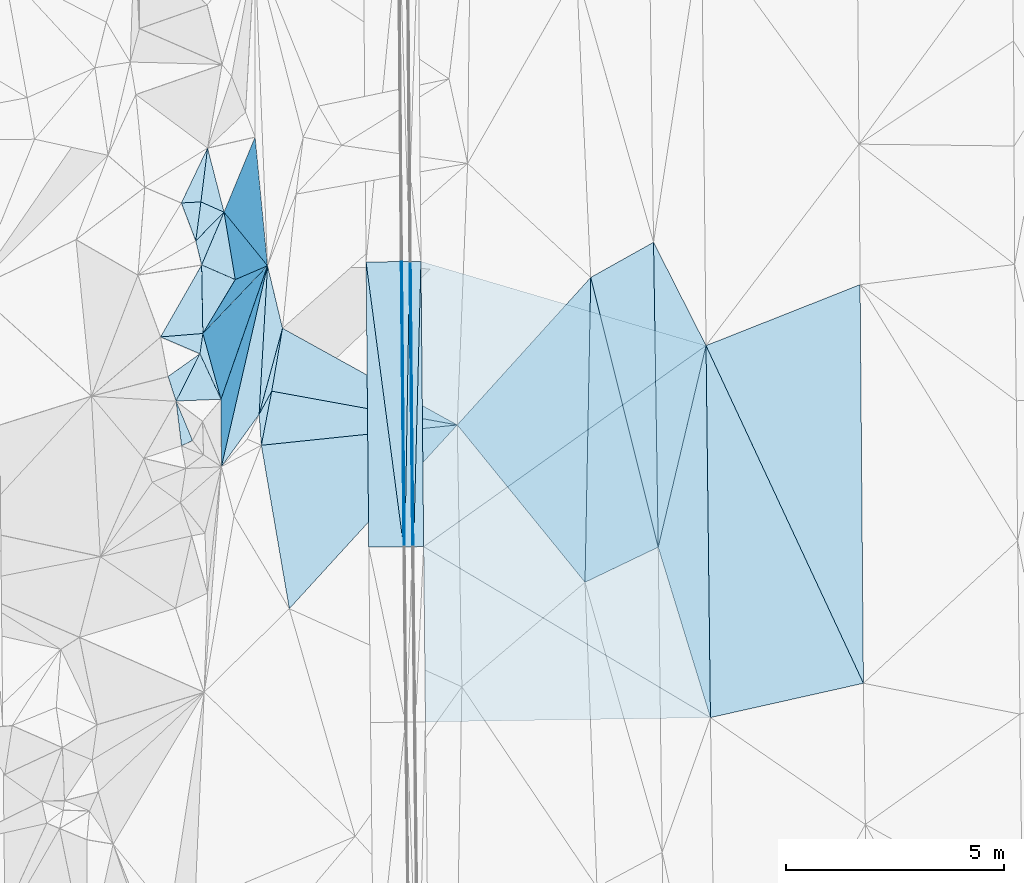
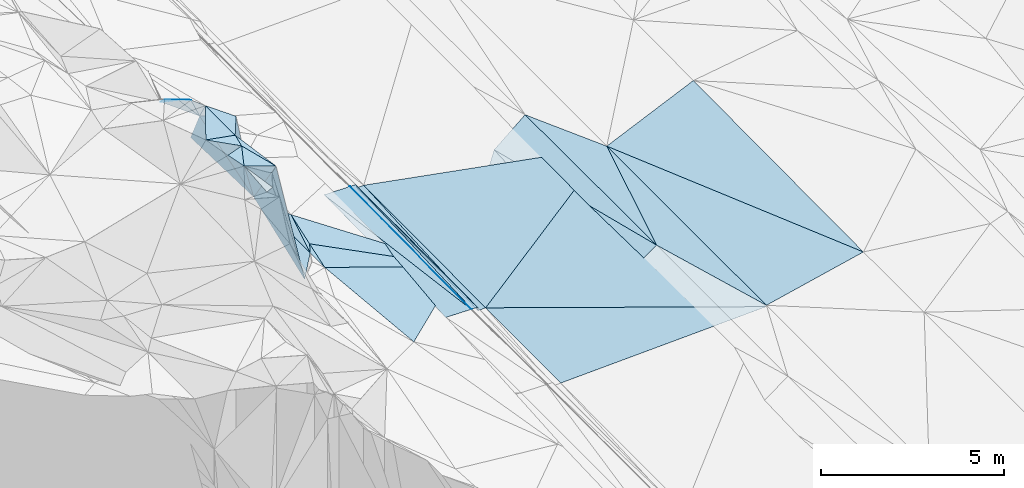
# One storey, part 21 of 275: 45 plates.
"""IFC2X3 building model written with IfcOpenShell, lengths in millimetres."""

from ifc_helpers import new_model, si_unit, frame, origin_with_axes, place, context, subcontext, project, spatial, polyline, outline, extrude, material, type_object, element, save


model = new_model("IFC2X3")

# Units and contexts
model_context = context("Model", 3, precision=1e-05, world=origin_with_axes())
body_context = subcontext(model_context, "Body", "Model", "MODEL_VIEW")
ifc_project = project(units=[si_unit("LENGTHUNIT", "METRE", prefix="MILLI"), si_unit("AREAUNIT", "SQUARE_METRE"), si_unit("VOLUMEUNIT", "CUBIC_METRE"), si_unit("MASSUNIT", "GRAM", prefix="KILO"), si_unit("TIMEUNIT", "SECOND"), si_unit("PLANEANGLEUNIT", "RADIAN"), si_unit("SOLIDANGLEUNIT", "STERADIAN"), si_unit("THERMODYNAMICTEMPERATUREUNIT", "DEGREE_CELSIUS"), si_unit("LUMINOUSINTENSITYUNIT", "LUMEN")], contexts=[model_context])

# Site, building, storey
site_placement = place(None, origin_with_axes())
site = spatial("IfcSite", under=ifc_project, at=site_placement, CompositionType="ELEMENT")
building_placement = place(site_placement, origin_with_axes())
building = spatial("IfcBuilding", under=site, at=building_placement, Name="Undefined", CompositionType="ELEMENT")
storey_placement = place(building_placement, origin_with_axes())
storey = spatial("IfcBuildingStorey", under=building, at=storey_placement, Name="Undefined", CompositionType="ELEMENT", Elevation=0.0)

# Plates
ifc_material = material()
plate_type_1 = type_object("IfcPlateType", PredefinedType="NOTDEFINED")
plate_1_placement = place(storey_placement, frame((-93826.0260139726, 22871.525011695, 41384.7557479221), z_axis=(-0.970140566406097, -0.00414182379027127, -0.242507993082596), x_axis=(-0.014017652109984, 0.999140397865206, 0.0390124439516598)))
element("IfcPlate", 1, at=plate_1_placement, inside=storey, type_object=plate_type_1, material=ifc_material, Name="00_PR", context=body_context, shape_type="SweptSolid", body=[
    extrude(outline(polyline([(0.0, 0.0), (6552.26806640625, 1.18961906991899e-08), (6547.705078125, 123.608764648438), (0.0, 0.0)])), frame((-8.85201319254618e-08, 2.18876761149539e-07, -0.5000001331573), z_axis=(0.0, 0.0, 1.0), x_axis=(1.0, 0.0, 0.0)), (0.0, 0.0, 1.0), 1.0),
])
plate_2_placement = place(storey_placement, frame((-93856.0194695431, 22870.9196575083, 41504.7557501283), z_axis=(-0.970141710660161, -0.00414201915198373, -0.242503412171293), x_axis=(-0.00944488511412005, 0.999740938347601, 0.0207087019641435)))
element("IfcPlate", 2, at=plate_2_placement, inside=storey, type_object=plate_type_1, material=ifc_material, Name="00_PR", context=body_context, shape_type="SweptSolid", body=[
    extrude(outline(polyline([(0.0, 0.0), (6548.93798828125, -1.03318598121405e-08), (-2.16313171386719, 123.67414855957), (0.0, 0.0)])), frame((-8.85201319254618e-08, 2.18876761149539e-07, -0.5000001331573), z_axis=(0.0, 0.0, 1.0), x_axis=(1.0, 0.0, 0.0)), (0.0, 0.0, 1.0), 1.0),
])
plate_type_2 = type_object("IfcPlateType", PredefinedType="NOTDEFINED")
plate_3_placement = place(storey_placement, frame((-94087.3915116084, 29416.65937764, 41639.9972075096), z_axis=(-0.0201751474359176, 0.0205142055832547, -0.999585979691205), x_axis=(0.00486424610334273, -0.999775628945479, -0.0206162769800514)))
element("IfcPlate", 3, at=plate_3_placement, inside=storey, type_object=plate_type_2, material=ifc_material, Name="00_PR", context=body_context, shape_type="SweptSolid", body=[
    extrude(outline(polyline([(0.0, 0.0), (6549.1943359375, 3.34694050252438e-09), (0.108272440731525, 30.0058708190918), (0.0, 0.0)])), frame((-8.85201319254618e-08, 2.18876761149539e-07, -0.5000001331573), z_axis=(0.0, 0.0, 1.0), x_axis=(1.0, 0.0, 0.0)), (0.0, 0.0, 1.0), 1.0),
])
plate_4_placement = place(storey_placement, frame((-94055.5346332526, 22868.9346980199, 41504.9772079253), z_axis=(-0.0201973002750477, 0.0205140903788785, -0.999585534688016), x_axis=(-0.00486424610268061, 0.99977562894545, 0.0206162769816057)))
element("IfcPlate", 4, at=plate_4_placement, inside=storey, type_object=plate_type_2, material=ifc_material, Name="00_PR", context=body_context, shape_type="SweptSolid", body=[
    extrude(outline(polyline([(0.0, 0.0), (6549.1943359375, 3.34694050252438e-09), (0.140960708260536, 30.0058040618896), (0.0, 0.0)])), frame((-8.85201319254618e-08, 2.18876761149539e-07, -0.5000001331573), z_axis=(0.0, 0.0, 1.0), x_axis=(1.0, 0.0, 0.0)), (0.0, 0.0, 1.0), 1.0),
])
plate_type_3 = type_object("IfcPlateType", PredefinedType="NOTDEFINED")
plate_5_placement = place(storey_placement, frame((-94917.359086969, 29409.2703324959, 41656.5972077812), z_axis=(-0.0201751474359176, 0.0205142055832547, -0.999585979691205), x_axis=(0.99976043542042, 0.00890124210765779, -0.0199959910210385)))
element("IfcPlate", 5, at=plate_5_placement, inside=storey, type_object=plate_type_3, material=ifc_material, Name="00_PR", context=body_context, shape_type="SweptSolid", body=[
    extrude(outline(polyline([(0.0, 0.0), (800.160400390625, 3.5979610402137e-09), (806.432678222656, 6549.1513671875), (0.0, 0.0)])), frame((-8.85201319254618e-08, 2.18876761149539e-07, -0.5000001331573), z_axis=(0.0, 0.0, 1.0), x_axis=(1.0, 0.0, 0.0)), (0.0, 0.0, 1.0), 1.0),
])
plate_6_placement = place(storey_placement, frame((-94055.5346332526, 22868.9346980199, 41504.9772079253), z_axis=(-0.020197663765246, 0.0205112299366591, -0.999585586042992), x_axis=(-0.99975015351439, -0.00998950710098539, 0.0199960069972186)))
element("IfcPlate", 6, at=plate_6_placement, inside=storey, type_object=plate_type_3, material=ifc_material, Name="00_PR", context=body_context, shape_type="SweptSolid", body=[
    extrude(outline(polyline([(0.0, 0.0), (800.159790039063, 5.60248736292124e-09), (799.306213378906, 6550.025390625), (0.0, 0.0)])), frame((-8.85201319254618e-08, 2.18876761149539e-07, -0.5000001331573), z_axis=(0.0, 0.0, 1.0), x_axis=(1.0, 0.0, 0.0)), (0.0, 0.0, 1.0), 1.0),
])
plate_type_4 = type_object("IfcPlateType", PredefinedType="NOTDEFINED")
plate_7_placement = place(storey_placement, frame((-93887.3778118008, 29418.7125557996, 41519.9973749034), z_axis=(0.0324229017125608, 0.0210051230873963, -0.99925349148683), x_axis=(0.999438984670198, 0.00771590211008949, 0.0325911149860068)))
element("IfcPlate", 7, at=plate_7_placement, inside=storey, type_object=plate_type_4, material=ifc_material, Name="00_PR", context=body_context, shape_type="SweptSolid", body=[
    extrude(outline(polyline([(0.0, 0.0), (230.124069213867, 3.71073838323355e-10), (6.88101148605347, 6548.8681640625), (0.0, 0.0)])), frame((-8.85201319254618e-08, 2.18876761149539e-07, -0.5000001331573), z_axis=(0.0, 0.0, 1.0), x_axis=(1.0, 0.0, 0.0)), (0.0, 0.0, 1.0), 1.0),
])
plate_8_placement = place(storey_placement, frame((-93657.3828568659, 29420.4881701947, 41527.497374587), z_axis=(0.0324032083024924, 0.0210056422550089, -0.999254119373626), x_axis=(0.00944502212352981, -0.999740918493301, -0.020709597950165)))
element("IfcPlate", 8, at=plate_8_placement, inside=storey, type_object=plate_type_4, material=ifc_material, Name="00_PR", context=body_context, shape_type="SweptSolid", body=[
    extrude(outline(polyline([(0.0, 0.0), (6548.654296875, -1.17142917588353e-08), (6548.6298828125, 230.124954223633), (0.0, 0.0)])), frame((-8.85201319254618e-08, 2.18876761149539e-07, -0.5000001331573), z_axis=(0.0, 0.0, 1.0), x_axis=(1.0, 0.0, 0.0)), (0.0, 0.0, 1.0), 1.0),
])
plate_type_5 = type_object("IfcPlateType", PredefinedType="NOTDEFINED")
plate_9_placement = place(storey_placement, frame((-97082.5660207515, 26443.461021009, 42579.5374403282), z_axis=(-0.378120799749058, 0.0352070273940307, -0.925086550555789), x_axis=(0.910617236448785, -0.165832654415489, -0.378517871984786)))
element("IfcPlate", 9, at=plate_9_placement, inside=storey, type_object=plate_type_5, material=ifc_material, Name="00", context=body_context, shape_type="SweptSolid", body=[
    extrude(outline(polyline([(0.0, 0.0), (4676.13330078125, -1.7611455405131e-08), (-29.6355972290039, 1265.55200195313), (0.0, 0.0)])), frame((-8.85201319254618e-08, 2.18876761149539e-07, -0.5000001331573), z_axis=(0.0, 0.0, 1.0), x_axis=(1.0, 0.0, 0.0)), (0.0, 0.0, 1.0), 1.0),
])
plate_type_6 = type_object("IfcPlateType", PredefinedType="NOTDEFINED")
plate_10_placement = place(storey_placement, frame((-94025.5259870622, 22869.2341150587, 41504.3771091948), z_axis=(-0.000184409306113274, 0.0207073018638492, -0.999785563829928), x_axis=(-0.00944488511412005, 0.999740938347601, 0.0207087019641435)))
element("IfcPlate", 10, at=plate_10_placement, inside=storey, type_object=plate_type_6, material=ifc_material, Name="00_PR", context=body_context, shape_type="SweptSolid", body=[
    extrude(outline(polyline([(0.0, 0.0), (6549.1220703125, 9.50240064412355e-09), (6549.02978515625, 169.999771118164), (0.0, 0.0)])), frame((-8.85201319254618e-08, 2.18876761149539e-07, -0.5000001331573), z_axis=(0.0, 0.0, 1.0), x_axis=(1.0, 0.0, 0.0)), (0.0, 0.0, 1.0), 1.0),
])
plate_11_placement = place(storey_placement, frame((-93917.3884652432, 29418.1733544356, 41639.9971090388), z_axis=(-0.00020683915581574, 0.0207076720193423, -0.999785551774531), x_axis=(0.0094448851130357, -0.999740938347447, -0.0207087019720617)))
element("IfcPlate", 11, at=plate_11_placement, inside=storey, type_object=plate_type_6, material=ifc_material, Name="00_PR", context=body_context, shape_type="SweptSolid", body=[
    extrude(outline(polyline([(0.0, 0.0), (6548.93798828125, -1.03318598121405e-08), (6549.02978515625, 169.999954223633), (0.0, 0.0)])), frame((-8.85201319254618e-08, 2.18876761149539e-07, -0.5000001331573), z_axis=(0.0, 0.0, 1.0), x_axis=(1.0, 0.0, 0.0)), (0.0, 0.0, 1.0), 1.0),
])
plate_type_7 = type_object("IfcPlateType", PredefinedType="NOTDEFINED")
plate_12_placement = place(storey_placement, frame((-87114.0575367, 27489.3894326454, 41681.911334362), z_axis=(0.0297045321519346, 0.0210821770108472, -0.999336371089394), x_axis=(0.0118277461036412, -0.99971496697017, -0.0207385929594911)))
element("IfcPlate", 12, at=plate_12_placement, inside=storey, type_object=plate_type_7, material=ifc_material, Name="00_PR", context=body_context, shape_type="SweptSolid", body=[
    extrude(outline(polyline([(0.0, 0.0), (8540.6953125, 1.83354131877422e-09), (4543.89697265625, 6538.5615234375), (0.0, 0.0)])), frame((-8.85201319254618e-08, 2.18876761149539e-07, -0.5000001331573), z_axis=(0.0, 0.0, 1.0), x_axis=(1.0, 0.0, 0.0)), (0.0, 0.0, 1.0), 1.0),
])
plate_type_8 = type_object("IfcPlateType", PredefinedType="NOTDEFINED")
plate_13_placement = place(storey_placement, frame((-93595.5319840842, 22873.5303718506, 41391.8773336054), z_axis=(0.0297755029540503, 0.0209825206615359, -0.999336356413856), x_axis=(-0.00944502211104148, 0.999740918492665, 0.0207095979865622)))
element("IfcPlate", 13, at=plate_13_placement, inside=storey, type_object=plate_type_8, material=ifc_material, Name="00_PR", context=body_context, shape_type="SweptSolid", body=[
    extrude(outline(polyline([(0.0, 0.0), (6548.654296875, -1.17142917588353e-08), (4559.4521484375, 6527.72412109375), (0.0, 0.0)])), frame((-8.85201319254618e-08, 2.18876761149539e-07, -0.5000001331573), z_axis=(0.0, 0.0, 1.0), x_axis=(1.0, 0.0, 0.0)), (0.0, 0.0, 1.0), 1.0),
])
plate_type_9 = type_object("IfcPlateType", PredefinedType="NOTDEFINED")
plate_14_placement = place(storey_placement, frame((-93554.0078757195, 18851.9524732335, 41308.34533342), z_axis=(0.0296935809003478, 0.0210637784470619, -0.999337084516955), x_axis=(-0.0103225611048847, 0.999731085996576, 0.020765365981426)))
element("IfcPlate", 14, at=plate_14_placement, inside=storey, type_object=plate_type_9, material=ifc_material, Name="00_PR", context=body_context, shape_type="SweptSolid", body=[
    extrude(outline(polyline([(0.0, 0.0), (4022.65966796875, 1.94995664060116e-09), (35.7092895507813, 6544.57080078125), (0.0, 0.0)])), frame((-8.85201319254618e-08, 2.18876761149539e-07, -0.5000001331573), z_axis=(0.0, 0.0, 1.0), x_axis=(1.0, 0.0, 0.0)), (0.0, 0.0, 1.0), 1.0),
])
plate_type_10 = type_object("IfcPlateType", PredefinedType="NOTDEFINED")
plate_15_placement = place(storey_placement, frame((-97320.5660652913, 25201.1452128023, 42629.5376581824), z_axis=(-0.378573184609817, 0.0412608111029516, -0.924651225793546), x_axis=(0.922674065168372, 0.0958066236613962, -0.373488500931789)))
element("IfcPlate", 15, at=plate_15_placement, inside=storey, type_object=plate_type_10, material=ifc_material, Name="00", context=body_context, shape_type="SweptSolid", body=[
    extrude(outline(polyline([(0.0, 0.0), (4872.974609375, -2.02344381250441e-08), (393.078186035156, 3809.3818359375), (0.0, 0.0)])), frame((-8.85201319254618e-08, 2.18876761149539e-07, -0.5000001331573), z_axis=(0.0, 0.0, 1.0), x_axis=(1.0, 0.0, 0.0)), (0.0, 0.0, 1.0), 1.0),
])
plate_type_11 = type_object("IfcPlateType", PredefinedType="NOTDEFINED")
plate_16_placement = place(storey_placement, frame((-98177.264648072, 30551.4287036856, 44729.660956907), z_axis=(-0.570776400395025, -0.463070710385296, -0.678070658512338), x_axis=(0.144897575084619, -0.869646163992398, 0.471932455111856)))
element("IfcPlate", 16, at=plate_16_placement, inside=storey, type_object=plate_type_11, material=ifc_material, Name="00", context=body_context, shape_type="SweptSolid", body=[
    extrude(outline(polyline([(0.0, 0.0), (1779.91577148438, -2.57568899542093e-09), (1573.5576171875, 918.213684082031), (0.0, 0.0)])), frame((-8.85201319254618e-08, 2.18876761149539e-07, -0.5000001331573), z_axis=(0.0, 0.0, 1.0), x_axis=(1.0, 0.0, 0.0)), (0.0, 0.0, 1.0), 1.0),
])
plate_type_12 = type_object("IfcPlateType", PredefinedType="NOTDEFINED")
plate_17_placement = place(storey_placement, frame((-98691.3294837368, 29340.350874152, 45989.5595610153), z_axis=(-0.473170190514732, 0.0138617626806763, -0.880861976897423), x_axis=(0.820322698251233, -0.357639718949033, -0.446278502914797)))
element("IfcPlate", 17, at=plate_17_placement, inside=storey, type_object=plate_type_12, material=ifc_material, Name="00", context=body_context, shape_type="SweptSolid", body=[
    extrude(outline(polyline([(0.0, 0.0), (941.116333007813, -5.59339241590351e-09), (603.644775390625, 1453.20776367188), (0.0, 0.0)])), frame((-8.85201319254618e-08, 2.18876761149539e-07, -0.5000001331573), z_axis=(0.0, 0.0, 1.0), x_axis=(1.0, 0.0, 0.0)), (0.0, 0.0, 1.0), 1.0),
])
plate_type_13 = type_object("IfcPlateType", PredefinedType="NOTDEFINED")
plate_18_placement = place(storey_placement, frame((-96835.1079451205, 27886.8305973037, 42589.5778468907), z_axis=(-0.527193697948621, 0.0962631631955029, -0.844274960101775), x_axis=(-0.169028241326927, -0.9855875531343, -0.00682852404770339)))
element("IfcPlate", 18, at=plate_18_placement, inside=storey, type_object=plate_type_13, material=ifc_material, Name="00", context=body_context, shape_type="SweptSolid", body=[
    extrude(outline(polyline([(0.0, 0.0), (1464.4453125, -1.30967237055302e-09), (2037.35852050781, 231.236877441406), (0.0, 0.0)])), frame((-8.85201319254618e-08, 2.18876761149539e-07, -0.5000001331573), z_axis=(0.0, 0.0, 1.0), x_axis=(1.0, 0.0, 0.0)), (0.0, 0.0, 1.0), 1.0),
])
plate_type_14 = type_object("IfcPlateType", PredefinedType="NOTDEFINED")
plate_19_placement = place(storey_placement, frame((-98177.3597581934, 30551.5064062295, 44729.7144107108), z_axis=(-0.760995237269169, -0.30766530577883, -0.571163994377849), x_axis=(-0.646549326055016, 0.287087911902404, 0.706791694785191)))
element("IfcPlate", 19, at=plate_19_placement, inside=storey, type_object=plate_type_14, material=ifc_material, Name="00", context=body_context, shape_type="SweptSolid", body=[
    extrude(outline(polyline([(0.0, 0.0), (820.609558105469, -1.58615875989199e-09), (462.217407226563, 1477.48266601563), (0.0, 0.0)])), frame((-8.85201319254618e-08, 2.18876761149539e-07, -0.5000001331573), z_axis=(0.0, 0.0, 1.0), x_axis=(1.0, 0.0, 0.0)), (0.0, 0.0, 1.0), 1.0),
])
plate_type_15 = type_object("IfcPlateType", PredefinedType="NOTDEFINED")
plate_20_placement = place(storey_placement, frame((-98691.2089325676, 29340.3542147563, 45989.5137509309), z_axis=(-0.232070244511385, 0.0205434203003785, -0.972482066412943), x_axis=(0.0180401271724156, -0.999514083181828, -0.0254195069345103)))
element("IfcPlate", 20, at=plate_20_placement, inside=storey, type_object=plate_type_15, material=ifc_material, Name="00", context=body_context, shape_type="SweptSolid", body=[
    extrude(outline(polyline([(0.0, 0.0), (1573.59460449219, 9.45874489843845e-10), (1629.517578125, 999.286071777344), (0.0, 0.0)])), frame((-8.85201319254618e-08, 2.18876761149539e-07, -0.5000001331573), z_axis=(0.0, 0.0, 1.0), x_axis=(1.0, 0.0, 0.0)), (0.0, 0.0, 1.0), 1.0),
])
plate_type_16 = type_object("IfcPlateType", PredefinedType="NOTDEFINED")
plate_21_placement = place(storey_placement, frame((-88211.9074751237, 22862.3692623378, 41600.5001334758), z_axis=(0.0140635701774405, 0.0202133065334317, -0.999696773143162), x_axis=(-0.0152677196760189, 0.999683433198513, 0.0199982530319309)))
element("IfcPlate", 21, at=plate_21_placement, inside=storey, type_object=plate_type_16, material=ifc_material, Name="00", context=body_context, shape_type="SweptSolid", body=[
    extrude(outline(polyline([(0.0, 0.0), (7000.611328125, 1.13213900476694e-08), (4610.97314453125, 1168.49291992188), (0.0, 0.0)])), frame((-8.85201319254618e-08, 2.18876761149539e-07, -0.5000001331573), z_axis=(0.0, 0.0, 1.0), x_axis=(1.0, 0.0, 0.0)), (0.0, 0.0, 1.0), 1.0),
])
plate_type_17 = type_object("IfcPlateType", PredefinedType="NOTDEFINED")
plate_22_placement = place(storey_placement, frame((-98663.1454011819, 27767.4308437988, 45949.778023672), z_axis=(-0.88050362967345, -0.166286809080158, -0.443916721083831), x_axis=(0.359377335002901, 0.376520943277298, -0.853861763027123)))
element("IfcPlate", 22, at=plate_22_placement, inside=storey, type_object=plate_type_17, material=ifc_material, Name="00", context=body_context, shape_type="SweptSolid", body=[
    extrude(outline(polyline([(0.0, 0.0), (4129.47412109375, -9.60426405072212e-10), (-197.148590087891, 1576.11303710938), (0.0, 0.0)])), frame((-8.85201319254618e-08, 2.18876761149539e-07, -0.5000001331573), z_axis=(0.0, 0.0, 1.0), x_axis=(1.0, 0.0, 0.0)), (0.0, 0.0, 1.0), 1.0),
])
plate_type_18 = type_object("IfcPlateType", PredefinedType="NOTDEFINED")
plate_23_placement = place(storey_placement, frame((-97464.3259668732, 32277.3413261733, 42719.8133561504), z_axis=(-0.926262492714875, -0.0520058937886138, -0.373273601532273), x_axis=(0.0955924211927201, -0.99046393511105, -0.0992133169229206)))
element("IfcPlate", 23, at=plate_23_placement, inside=storey, type_object=plate_type_18, material=ifc_material, Name="00", context=body_context, shape_type="SweptSolid", body=[
    extrude(outline(polyline([(0.0, 0.0), (2983.47045898438, -7.27595761418343e-11), (1441.66333007813, 2334.16088867188), (0.0, 0.0)])), frame((-8.85201319254618e-08, 2.18876761149539e-07, -0.5000001331573), z_axis=(0.0, 0.0, 1.0), x_axis=(1.0, 0.0, 0.0)), (0.0, 0.0, 1.0), 1.0),
])
plate_type_19 = type_object("IfcPlateType", PredefinedType="NOTDEFINED")
plate_24_placement = place(storey_placement, frame((-98554.9892956429, 32024.3941330472, 44439.6005880922), z_axis=(-0.292857951043184, -0.525488379507461, -0.798809228485382), x_axis=(-0.100439406980494, -0.81390911720912, 0.57224459320231)))
element("IfcPlate", 24, at=plate_24_placement, inside=storey, type_object=plate_type_19, material=ifc_material, Name="00", context=body_context, shape_type="SweptSolid", body=[
    extrude(outline(polyline([(0.0, 0.0), (1520.32885742188, -5.67524693906307e-10), (1687.52954101563, 454.361022949219), (0.0, 0.0)])), frame((-8.85201319254618e-08, 2.18876761149539e-07, -0.5000001331573), z_axis=(0.0, 0.0, 1.0), x_axis=(1.0, 0.0, 0.0)), (0.0, 0.0, 1.0), 1.0),
])
plate_type_20 = type_object("IfcPlateType", PredefinedType="NOTDEFINED")
plate_25_placement = place(storey_placement, frame((-98707.9249667768, 30787.1083117734, 45309.7077762389), z_axis=(-0.762331766193661, -0.278007508448131, -0.584433147159293), x_axis=(0.64654932605515, -0.287087911904663, -0.70679169478415)))
element("IfcPlate", 25, at=plate_25_placement, inside=storey, type_object=plate_type_20, material=ifc_material, Name="00", context=body_context, shape_type="SweptSolid", body=[
    extrude(outline(polyline([(0.0, 0.0), (820.609558105469, -1.58615875989199e-09), (-229.829162597656, 1047.55834960938), (0.0, 0.0)])), frame((-8.85201319254618e-08, 2.18876761149539e-07, -0.5000001331573), z_axis=(0.0, 0.0, 1.0), x_axis=(1.0, 0.0, 0.0)), (0.0, 0.0, 1.0), 1.0),
])
plate_type_21 = type_object("IfcPlateType", PredefinedType="NOTDEFINED")
plate_26_placement = place(storey_placement, frame((-98177.4418619828, 30551.5161625654, 44729.8765301978), z_axis=(-0.925200329172637, -0.288153202578294, -0.246925257401337), x_axis=(0.35687128332475, -0.439447525173016, -0.824335344236469)))
element("IfcPlate", 26, at=plate_26_placement, inside=storey, type_object=plate_type_21, material=ifc_material, Name="00", context=body_context, shape_type="SweptSolid", body=[
    extrude(outline(polyline([(0.0, 0.0), (2797.4052734375, 6.73026079311967e-09), (79.8168258666992, 1778.12524414063), (0.0, 0.0)])), frame((-8.85201319254618e-08, 2.18876761149539e-07, -0.5000001331573), z_axis=(0.0, 0.0, 1.0), x_axis=(1.0, 0.0, 0.0)), (0.0, 0.0, 1.0), 1.0),
])
plate_type_22 = type_object("IfcPlateType", PredefinedType="NOTDEFINED")
plate_27_placement = place(storey_placement, frame((-98826.2157070042, 29892.7132241473, 45889.591217486), z_axis=(-0.302221824999577, -0.490176755495786, -0.817550436893987), x_axis=(-0.325874869922666, 0.859111547488657, -0.394630102912247)))
element("IfcPlate", 27, at=plate_27_placement, inside=storey, type_object=plate_type_22, material=ifc_material, Name="00", context=body_context, shape_type="SweptSolid", body=[
    extrude(outline(polyline([(0.0, 0.0), (1013.607421875, -1.45519152283669e-10), (958.556518554688, 481.008728027344), (0.0, 0.0)])), frame((-8.85201319254618e-08, 2.18876761149539e-07, -0.5000001331573), z_axis=(0.0, 0.0, 1.0), x_axis=(1.0, 0.0, 0.0)), (0.0, 0.0, 1.0), 1.0),
])
plate_type_23 = type_object("IfcPlateType", PredefinedType="NOTDEFINED")
plate_28_placement = place(storey_placement, frame((-97179.0991033745, 29322.5841688497, 42423.9219565493), z_axis=(-0.866872690746787, 0.473469693603035, -0.156071096865734), x_axis=(-0.359377335108035, -0.376520943053492, 0.853861763081564)))
element("IfcPlate", 28, at=plate_28_placement, inside=storey, type_object=plate_type_23, material=ifc_material, Name="00", context=body_context, shape_type="SweptSolid", body=[
    extrude(outline(polyline([(0.0, 0.0), (4129.47412109375, -9.60426405072212e-10), (3072.28857421875, 1052.64379882813), (0.0, 0.0)])), frame((-8.85201319254618e-08, 2.18876761149539e-07, -0.5000001331573), z_axis=(0.0, 0.0, 1.0), x_axis=(1.0, 0.0, 0.0)), (0.0, 0.0, 1.0), 1.0),
])
plate_type_24 = type_object("IfcPlateType", PredefinedType="NOTDEFINED")
plate_29_placement = place(storey_placement, frame((-98691.4704431463, 29340.1985634103, 45989.7061811562), z_axis=(-0.755089217474095, -0.290759432940294, -0.587621668942355), x_axis=(-0.233684383184475, 0.956773531153196, -0.173135840138129)))
element("IfcPlate", 29, at=plate_29_placement, inside=storey, type_object=plate_type_24, material=ifc_material, Name="00", context=body_context, shape_type="SweptSolid", body=[
    extrude(outline(polyline([(0.0, 0.0), (577.581176757813, 8.00355337560177e-10), (1256.96618652344, 1318.80090332031), (0.0, 0.0)])), frame((-8.85201319254618e-08, 2.18876761149539e-07, -0.5000001331573), z_axis=(0.0, 0.0, 1.0), x_axis=(1.0, 0.0, 0.0)), (0.0, 0.0, 1.0), 1.0),
])
plate_type_25 = type_object("IfcPlateType", PredefinedType="NOTDEFINED")
plate_30_placement = place(storey_placement, frame((-98729.738878546, 27300.6537959587, 45899.5193454562), z_axis=(-0.238949383663227, 0.137181099173112, -0.96129315927901), x_axis=(-0.883941752868518, 0.379042577772413, 0.273813260766124)))
element("IfcPlate", 30, at=plate_30_placement, inside=storey, type_object=plate_type_25, material=ifc_material, Name="00", context=body_context, shape_type="SweptSolid", body=[
    extrude(outline(polyline([(0.0, 0.0), (1022.5947265625, -5.79166226089001e-09), (131.52815246582, 455.741546630859), (0.0, 0.0)])), frame((-8.85201319254618e-08, 2.18876761149539e-07, -0.5000001331573), z_axis=(0.0, 0.0, 1.0), x_axis=(1.0, 0.0, 0.0)), (0.0, 0.0, 1.0), 1.0),
])
plate_type_26 = type_object("IfcPlateType", PredefinedType="NOTDEFINED")
plate_31_placement = place(storey_placement, frame((-98729.7965698941, 27300.5972141954, 45899.5325861669), z_axis=(-0.35432948649937, 0.0240177693129232, -0.934812153191391), x_axis=(0.413353011135522, -0.892680717857241, -0.179611870852338)))
element("IfcPlate", 31, at=plate_31_placement, inside=storey, type_object=plate_type_26, material=ifc_material, Name="00", context=body_context, shape_type="SweptSolid", body=[
    extrude(outline(polyline([(0.0, 0.0), (1169.18774414063, 2.19733919948339e-09), (708.953735351563, 1003.13739013672), (0.0, 0.0)])), frame((-8.85201319254618e-08, 2.18876761149539e-07, -0.5000001331573), z_axis=(0.0, 0.0, 1.0), x_axis=(1.0, 0.0, 0.0)), (0.0, 0.0, 1.0), 1.0),
])
plate_type_27 = type_object("IfcPlateType", PredefinedType="NOTDEFINED")
plate_32_placement = place(storey_placement, frame((-98246.4082028426, 26256.9372266385, 45689.5098956266), z_axis=(-0.152152198420462, 0.126766357761746, -0.980193857895285), x_axis=(-0.413353011136143, 0.892680717856873, 0.179611870852742)))
element("IfcPlate", 32, at=plate_32_placement, inside=storey, type_object=plate_type_27, material=ifc_material, Name="00", context=body_context, shape_type="SweptSolid", body=[
    extrude(outline(polyline([(0.0, 0.0), (1169.18774414063, 2.19733919948339e-09), (1567.32739257813, 257.846496582031), (0.0, 0.0)])), frame((-8.85201319254618e-08, 2.18876761149539e-07, -0.5000001331573), z_axis=(0.0, 0.0, 1.0), x_axis=(1.0, 0.0, 0.0)), (0.0, 0.0, 1.0), 1.0),
])
plate_type_28 = type_object("IfcPlateType", PredefinedType="NOTDEFINED")
plate_33_placement = place(storey_placement, frame((-99278.1791479213, 26216.2646776269, 46079.5311954014), z_axis=(-0.347161574928232, 0.0199309813266569, -0.937593513670346), x_axis=(-0.306954911335743, 0.942287949450005, 0.133686583949817)))
element("IfcPlate", 33, at=plate_33_placement, inside=storey, type_object=plate_type_28, material=ifc_material, Name="00", context=body_context, shape_type="SweptSolid", body=[
    extrude(outline(polyline([(0.0, 0.0), (598.41455078125, -1.14960130304098e-09), (829.358154296875, 906.126403808594), (0.0, 0.0)])), frame((-8.85201319254618e-08, 2.18876761149539e-07, -0.5000001331573), z_axis=(0.0, 0.0, 1.0), x_axis=(1.0, 0.0, 0.0)), (0.0, 0.0, 1.0), 1.0),
])
plate_type_29 = type_object("IfcPlateType", PredefinedType="NOTDEFINED")
plate_34_placement = place(storey_placement, frame((-97179.1507291503, 29322.4533387555, 42423.9408269867), z_axis=(-0.970120855404335, 0.211809670318416, -0.118330847496188), x_axis=(-0.222797791828268, -0.970806643893803, 0.0888572120207336)))
element("IfcPlate", 34, at=plate_34_placement, inside=storey, type_object=plate_type_29, material=ifc_material, Name="00", context=body_context, shape_type="SweptSolid", body=[
    extrude(outline(polyline([(0.0, 0.0), (4749.1923828125, 4.9622030928731e-09), (3504.0634765625, 2987.52978515625), (0.0, 0.0)])), frame((-8.85201319254618e-08, 2.18876761149539e-07, -0.5000001331573), z_axis=(0.0, 0.0, 1.0), x_axis=(1.0, 0.0, 0.0)), (0.0, 0.0, 1.0), 1.0),
])
plate_type_30 = type_object("IfcPlateType", PredefinedType="NOTDEFINED")
plate_35_placement = place(storey_placement, frame((-98900.1030247831, 25311.9806162344, 45789.5205967411), z_axis=(-0.124080093509662, 0.255584991330615, -0.958791136067268), x_axis=(-0.899592780012155, -0.43672969918475, -1.20392313299024e-10)))
element("IfcPlate", 35, at=plate_35_placement, inside=storey, type_object=plate_type_30, material=ifc_material, Name="00", context=body_context, shape_type="SweptSolid", body=[
    extrude(outline(polyline([(0.0, 0.0), (280.178527832031, -8.14907252788544e-10), (-54.964958190918, 1020.72467041016), (0.0, 0.0)])), frame((-8.85201319254618e-08, 2.18876761149539e-07, -0.5000001331573), z_axis=(0.0, 0.0, 1.0), x_axis=(1.0, 0.0, 0.0)), (0.0, 0.0, 1.0), 1.0),
])
plate_type_31 = type_object("IfcPlateType", PredefinedType="NOTDEFINED")
plate_36_placement = place(storey_placement, frame((-92824.3954184479, 25668.0229330273, 40809.5371892876), z_axis=(-0.371957373849563, 0.070203528055198, -0.925591257892781), x_axis=(-0.910617236451052, 0.165832654417682, 0.378517871978371)))
element("IfcPlate", 36, at=plate_36_placement, inside=storey, type_object=plate_type_31, material=ifc_material, Name="00", context=body_context, shape_type="SweptSolid", body=[
    extrude(outline(polyline([(0.0, 0.0), (4676.13330078125, -1.7611455405131e-08), (4693.86376953125, 1464.337890625), (0.0, 0.0)])), frame((-8.85201319254618e-08, 2.18876761149539e-07, -0.5000001331573), z_axis=(0.0, 0.0, 1.0), x_axis=(1.0, 0.0, 0.0)), (0.0, 0.0, 1.0), 1.0),
])
plate_type_32 = type_object("IfcPlateType", PredefinedType="NOTDEFINED")
plate_37_placement = place(storey_placement, frame((-98236.8059374815, 24711.7613382106, 42845.5024067039), z_axis=(-0.0611514008498094, -0.0770512458281856, -0.995150044812555), x_axis=(0.222797791437334, 0.970806643992153, -0.0888572119264364)))
element("IfcPlate", 37, at=plate_37_placement, inside=storey, type_object=plate_type_32, material=ifc_material, Name="00", context=body_context, shape_type="SweptSolid", body=[
    extrude(outline(polyline([(0.0, 0.0), (4749.1923828125, 4.9622030928731e-09), (1369.83862304688, 575.363647460938), (0.0, 0.0)])), frame((-8.85201319254618e-08, 2.18876761149539e-07, -0.5000001331573), z_axis=(0.0, 0.0, 1.0), x_axis=(1.0, 0.0, 0.0)), (0.0, 0.0, 1.0), 1.0),
])
plate_type_33 = type_object("IfcPlateType", PredefinedType="NOTDEFINED")
plate_38_placement = place(storey_placement, frame((-97371.7232463694, 25910.9105313373, 42699.5052539832), z_axis=(0.116045841649672, -0.0866218027119137, -0.989459461489331), x_axis=(0.0563350083118735, 0.995160236661075, -0.0805137889257157)))
element("IfcPlate", 38, at=plate_38_placement, inside=storey, type_object=plate_type_33, material=ifc_material, Name="00", context=body_context, shape_type="SweptSolid", body=[
    extrude(outline(polyline([(0.0, 0.0), (3427.98413085938, 3.60887497663498e-09), (2005.37097167969, 427.536407470703), (0.0, 0.0)])), frame((-8.85201319254618e-08, 2.18876761149539e-07, -0.5000001331573), z_axis=(0.0, 0.0, 1.0), x_axis=(1.0, 0.0, 0.0)), (0.0, 0.0, 1.0), 1.0),
])
plate_type_34 = type_object("IfcPlateType", PredefinedType="NOTDEFINED")
plate_39_placement = place(storey_placement, frame((-88211.9048374015, 22862.3686361382, 41600.5001647653), z_axis=(0.0193350367790967, 0.0189610620124879, -0.999633249987269), x_axis=(0.230797791435303, 0.972731867496485, 0.0229149170931955)))
element("IfcPlate", 39, at=plate_39_placement, inside=storey, type_object=plate_type_34, material=ifc_material, Name="00", context=body_context, shape_type="SweptSolid", body=[
    extrude(outline(polyline([(0.0, 0.0), (4756.72705078125, 9.60426405072212e-09), (-3529.06323242188, 2069.63330078125), (0.0, 0.0)])), frame((-8.85201319254618e-08, 2.18876761149539e-07, -0.5000001331573), z_axis=(0.0, 0.0, 1.0), x_axis=(1.0, 0.0, 0.0)), (0.0, 0.0, 1.0), 1.0),
])
plate_type_35 = type_object("IfcPlateType", PredefinedType="NOTDEFINED")
plate_40_placement = place(storey_placement, frame((-97320.6092114175, 25201.1513265225, 42629.558101068), z_axis=(-0.464864068889404, 0.0534881349595397, -0.883764910411212), x_axis=(-0.0718820906673293, 0.99259831960473, 0.0978853459878491)))
element("IfcPlate", 40, at=plate_40_placement, inside=storey, type_object=plate_type_35, material=ifc_material, Name="00", context=body_context, shape_type="SweptSolid", body=[
    extrude(outline(polyline([(0.0, 0.0), (715.122375488281, -4.05270839110017e-09), (1211.12133789063, 368.354400634766), (0.0, 0.0)])), frame((-8.85201319254618e-08, 2.18876761149539e-07, -0.5000001331573), z_axis=(0.0, 0.0, 1.0), x_axis=(1.0, 0.0, 0.0)), (0.0, 0.0, 1.0), 1.0),
])
plate_type_36 = type_object("IfcPlateType", PredefinedType="NOTDEFINED")
plate_41_placement = place(storey_placement, frame((-87114.064621087, 27489.3883740688, 41709.5001328261), z_axis=(0.0156872682403897, 0.0189191173297432, -0.999697942687999), x_axis=(0.422421879586339, -0.906338241704177, -0.0105236529458752)))
element("IfcPlate", 41, at=plate_41_placement, inside=storey, type_object=plate_type_36, material=ifc_material, Name="00", context=body_context, shape_type="SweptSolid", body=[
    extrude(outline(polyline([(0.0, 0.0), (8552.1630859375, -9.21136233955622e-09), (7782.90771484375, 3516.25439453125), (0.0, 0.0)])), frame((-8.85201319254618e-08, 2.18876761149539e-07, -0.5000001331573), z_axis=(0.0, 0.0, 1.0), x_axis=(1.0, 0.0, 0.0)), (0.0, 0.0, 1.0), 1.0),
])
plate_type_37 = type_object("IfcPlateType", PredefinedType="NOTDEFINED")
plate_42_placement = place(storey_placement, frame((-87114.0624704511, 27489.389375585, 41709.5001912418), z_axis=(0.0199881455446429, 0.0209222952469697, -0.999581278135643), x_axis=(0.929522644085653, 0.367826981739221, 0.0262862252260086)))
element("IfcPlate", 42, at=plate_42_placement, inside=storey, type_object=plate_type_37, material=ifc_material, Name="00", context=body_context, shape_type="SweptSolid", body=[
    extrude(outline(polyline([(0.0, 0.0), (3804.27392578125, 2.06055119633675e-08), (504.564086914063, 8537.2666015625), (0.0, 0.0)])), frame((-8.85201319254618e-08, 2.18876761149539e-07, -0.5000001331573), z_axis=(0.0, 0.0, 1.0), x_axis=(1.0, 0.0, 0.0)), (0.0, 0.0, 1.0), 1.0),
])
plate_type_38 = type_object("IfcPlateType", PredefinedType="NOTDEFINED")
plate_43_placement = place(storey_placement, frame((-89760.5994570647, 29053.8558402734, 41566.5030196101), z_axis=(0.107895762605372, 0.0215309825189664, -0.993929032277241), x_axis=(0.867843782498406, 0.485673655354625, 0.104729507176045)))
element("IfcPlate", 43, at=plate_43_placement, inside=storey, type_object=plate_type_38, material=ifc_material, Name="00", context=body_context, shape_type="SweptSolid", body=[
    extrude(outline(polyline([(0.0, 0.0), (1661.4228515625, -5.47152012586594e-09), (-1659.41735839844, 6162.8388671875), (0.0, 0.0)])), frame((-8.85201319254618e-08, 2.18876761149539e-07, -0.5000001331573), z_axis=(0.0, 0.0, 1.0), x_axis=(1.0, 0.0, 0.0)), (0.0, 0.0, 1.0), 1.0),
])
plate_type_39 = type_object("IfcPlateType", PredefinedType="NOTDEFINED")
plate_44_placement = place(storey_placement, frame((-88211.8568512945, 22862.3708465655, 41600.503460505), z_axis=(0.115306820459529, 0.0233895879581809, -0.993054512265395), x_axis=(-0.895684434444452, -0.429796604327438, -0.114123936150685)))
element("IfcPlate", 44, at=plate_44_placement, inside=storey, type_object=plate_type_39, material=ifc_material, Name="00", context=body_context, shape_type="SweptSolid", body=[
    extrude(outline(polyline([(0.0, 0.0), (1875.15441894531, -7.79255060479045e-09), (-1270.01806640625, 6254.7021484375), (0.0, 0.0)])), frame((-8.85201319254618e-08, 2.18876761149539e-07, -0.5000001331573), z_axis=(0.0, 0.0, 1.0), x_axis=(1.0, 0.0, 0.0)), (0.0, 0.0, 1.0), 1.0),
])
plate_type_40 = type_object("IfcPlateType", PredefinedType="NOTDEFINED")
plate_45_placement = place(storey_placement, frame((-89891.3521817781, 22056.4346818786, 41386.5121092471), z_axis=(0.21786735111923, 0.0210272620868255, -0.975751849378428), x_axis=(-0.625586394738051, 0.770384916071701, -0.123080233213326)))
element("IfcPlate", 45, at=plate_45_placement, inside=storey, type_object=plate_type_40, material=ifc_material, Name="00", context=body_context, shape_type="SweptSolid", body=[
    extrude(outline(polyline([(0.0, 0.0), (4687.9990234375, 2.35304469242692e-08), (5286.7216796875, 4589.5517578125), (0.0, 0.0)])), frame((-8.85201319254618e-08, 2.18876761149539e-07, -0.5000001331573), z_axis=(0.0, 0.0, 1.0), x_axis=(1.0, 0.0, 0.0)), (0.0, 0.0, 1.0), 1.0),
])

save(model, "model.ifc")
